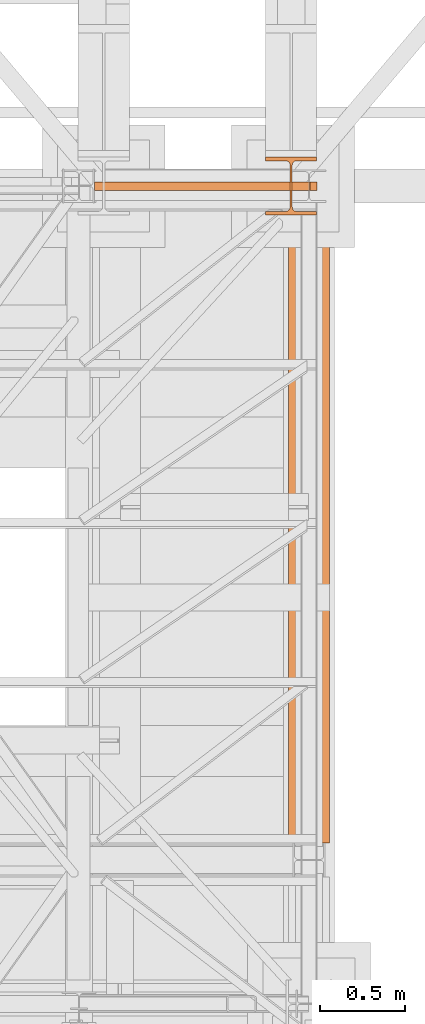
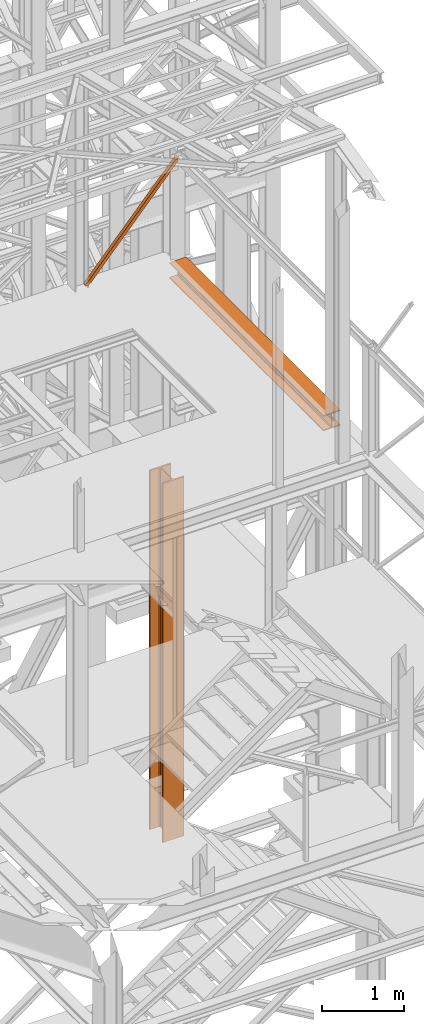
# One storey, part 77 of 208: 4 proxies.
"""IFC2X3 building model written with IfcOpenShell, lengths in millimetres."""

from ifc_helpers import new_model, entity, si_unit, converted_unit, frame, origin, origin_with_axes, place, context, subcontext, project, spatial, faceted_brep, material, element, save


model = new_model("IFC2X3")

# Units and contexts
model_context = context("Model", 3, precision=1e-05, world=origin())
plan_context = context("Plan", 3, precision=1e-05, world=origin())
body_context = subcontext(model_context, "Body", "Model", "MODEL_VIEW")
ifc_project = project(units=[si_unit("LENGTHUNIT", "METRE", prefix="MILLI"), converted_unit("PLANEANGLEUNIT", "DEGREE", entity("IfcPlaneAngleMeasure", 0.0174532925199433), si_unit("PLANEANGLEUNIT", "RADIAN"), dimensions=[0, 0, 0, 0, 0, 0, 0]), si_unit("AREAUNIT", "SQUARE_METRE"), si_unit("VOLUMEUNIT", "CUBIC_METRE")], contexts=[model_context, plan_context])

# Building, storey
building_placement = place(None, origin())
building = spatial("IfcBuilding", under=ifc_project, at=building_placement, CompositionType="COMPLEX")
storey_placement = place(building_placement, origin_with_axes())
storey = spatial("IfcBuildingStorey", under=building, at=storey_placement, Name="Geschoss", CompositionType="ELEMENT")

# Proxies
proxy_1_placement = place(storey_placement, frame((5439.095270376241, -17287.57439069042, 8485.574208086276), z_axis=(0.0, 0.0, 1.0), x_axis=(1.0, 0.0, 0.0)))
element("IfcBuildingElementProxy", 1, at=proxy_1_placement, inside=storey, context=body_context, shape_type="Brep", body=[
    faceted_brep([(0.01000000000203727, 0.01000000000203727, 19.53013193269908), (0.01000000000021828, 50.0100007450601, 19.53013193269908), (1263.785232156482, 50.01000074506374, 1439.925067016871), (1263.785232156482, 0.01000000000567525, 1439.925067016871), (0.01000000000021828, 50.0100007450601, 19.53013193269908), (0.01000000000203727, 50.0100007450601, 0.00999999999839929), (49.56811921901408, 50.0100007450601, 0.00999999999839929), (1303.220088081416, 50.01000074506374, 1409.027095462408), (1304.510962990664, 50.01000074506374, 1438.117904338131), (1263.785232156482, 50.01000074506374, 1439.925067016871), (49.56811921901408, 50.0100007450601, 0.00999999999839929), (49.56811921901408, 0.01000000000203727, 0.00999999999839929), (1303.220088081418, 0.01000000000567525, 1409.02709546241), (1303.220088081416, 50.01000074506374, 1409.027095462408), (49.56811921901408, 0.01000000000203727, 0.00999999999839929), (0.01000000000203727, 0.01000000000203727, 0.00999999999839929), (0.01000000000203727, 0.01000000000203727, 19.53013193269908), (1263.785232156482, 0.01000000000567525, 1439.925067016871), (1304.510962990664, 0.01000000000567525, 1438.117904338131), (1303.220088081418, 0.01000000000567525, 1409.02709546241), (1263.785232156482, 0.01000000000567525, 1439.925067016871), (1263.785232156482, 50.01000074506374, 1439.925067016871), (1304.510962990664, 50.01000074506374, 1438.117904338131), (1304.510962990664, 0.01000000000567525, 1438.117904338131), (1304.510962990664, 50.01000074506374, 1438.117904338131), (1303.220088081416, 50.01000074506374, 1409.027095462408), (1303.220088081418, 0.01000000000567525, 1409.02709546241), (1304.510962990664, 0.01000000000567525, 1438.117904338131), (0.01000000000203727, 50.0100007450601, 0.00999999999839929), (0.01000000000203727, 0.01000000000203727, 0.00999999999839929), (49.56811921901408, 0.01000000000203727, 0.00999999999839929), (49.56811921901408, 50.0100007450601, 0.00999999999839929), (0.01000000000021828, 50.0100007450601, 19.53013193269908), (0.01000000000203727, 0.01000000000203727, 19.53013193269908), (0.01000000000203727, 0.01000000000203727, 0.00999999999839929), (0.01000000000203727, 50.0100007450601, 0.00999999999839929)], [[[0, 1, 2, 3]], [[4, 5, 6, 7, 8, 9]], [[10, 11, 12, 13]], [[14, 15, 16, 17, 18, 19]], [[20, 21, 22, 23]], [[24, 25, 26, 27]], [[28, 29, 30, 31]], [[32, 33, 34, 35]]], orient=[[False], [False], [False], [False], [False], [False], [False], [False]]),
])
proxy_2_placement = place(storey_placement, frame((5439.095270376241, -17287.57439069042, 8485.574208086276), z_axis=(0.0, 0.0, 1.0), x_axis=(1.0, 0.0, 0.0)))
element("IfcBuildingElementProxy", 2, at=proxy_2_placement, inside=storey, context=body_context, shape_type="Brep", body=[
    faceted_brep([(0.01000000000203727, 0.01000000000203727, 19.53013193269908), (0.01000000000021828, 50.0100007450601, 19.53013193269908), (1263.785232156482, 50.01000074506374, 1439.925067016871), (1263.785232156482, 0.01000000000567525, 1439.925067016871), (0.01000000000021828, 50.0100007450601, 19.53013193269908), (0.01000000000203727, 50.0100007450601, 0.00999999999839929), (49.56811921901408, 50.0100007450601, 0.00999999999839929), (1303.220088081416, 50.01000074506374, 1409.027095462408), (1304.510962990664, 50.01000074506374, 1438.117904338131), (1263.785232156482, 50.01000074506374, 1439.925067016871), (49.56811921901408, 50.0100007450601, 0.00999999999839929), (49.56811921901408, 0.01000000000203727, 0.00999999999839929), (1303.220088081418, 0.01000000000567525, 1409.02709546241), (1303.220088081416, 50.01000074506374, 1409.027095462408), (49.56811921901408, 0.01000000000203727, 0.00999999999839929), (0.01000000000203727, 0.01000000000203727, 0.00999999999839929), (0.01000000000203727, 0.01000000000203727, 19.53013193269908), (1263.785232156482, 0.01000000000567525, 1439.925067016871), (1304.510962990664, 0.01000000000567525, 1438.117904338131), (1303.220088081418, 0.01000000000567525, 1409.02709546241), (1263.785232156482, 0.01000000000567525, 1439.925067016871), (1263.785232156482, 50.01000074506374, 1439.925067016871), (1304.510962990664, 50.01000074506374, 1438.117904338131), (1304.510962990664, 0.01000000000567525, 1438.117904338131), (1304.510962990664, 50.01000074506374, 1438.117904338131), (1303.220088081416, 50.01000074506374, 1409.027095462408), (1303.220088081418, 0.01000000000567525, 1409.02709546241), (1304.510962990664, 0.01000000000567525, 1438.117904338131), (0.01000000000203727, 50.0100007450601, 0.00999999999839929), (0.01000000000203727, 0.01000000000203727, 0.00999999999839929), (49.56811921901408, 0.01000000000203727, 0.00999999999839929), (49.56811921901408, 50.0100007450601, 0.00999999999839929), (0.01000000000021828, 50.0100007450601, 19.53013193269908), (0.01000000000203727, 0.01000000000203727, 19.53013193269908), (0.01000000000203727, 0.01000000000203727, 0.00999999999839929), (0.01000000000203727, 50.0100007450601, 0.00999999999839929)], [[[0, 1, 2, 3]], [[4, 5, 6, 7, 8, 9]], [[10, 11, 12, 13]], [[14, 15, 16, 17, 18, 19]], [[20, 21, 22, 23]], [[24, 25, 26, 27]], [[28, 29, 30, 31]], [[32, 33, 34, 35]]], orient=[[False], [False], [False], [False], [False], [False], [False], [False]]),
])
ifc_material = material(Name="35/80cm")
proxy_3_placement = place(storey_placement, frame((6443.254962568202, -17432.57439531565, -65.01000000000022), z_axis=(0.0, 0.0, 1.0), x_axis=(1.0, 0.0, 0.0)))
element("IfcBuildingElementProxy", 3, at=proxy_3_placement, inside=storey, material=ifc_material, context=body_context, shape_type="Brep", body=[
    faceted_brep([(300.0100119209292, 0.00999999999839929, 0.01000000000027512), (300.0100119209292, 21.51000631809075, 0.01000000000027512), (183.0100057816508, 21.51000631809075, 0.01000000000027512), (169.036290997863, 24.30682016372521, 0.01000000000027512), (158.8068282401564, 34.5362885093673, 0.01000000000027512), (156.0100060126188, 48.51000143050987, 0.01000000000027512), (156.0100060126188, 291.509994695185, 0.01000000000027512), (158.8068282401564, 305.4837150669082, 0.01000000000027512), (169.036290997863, 315.7131685113891, 0.01000000000027512), (183.0100057816508, 318.5099972581847, 0.01000000000027512), (300.0100119209292, 318.5099972581847, 0.01000000000027512), (300.0100119209292, 340.0100035762771, 0.01000000000027512), (0.01000000000021828, 340.0100035762771, 0.01000000000027512), (0.01000000000021828, 318.5099972581847, 0.01000000000027512), (117.0100061392786, 318.5099972581847, 0.01000000000027512), (130.9837209230664, 315.7131685113891, 0.01000000000027512), (141.213183680773, 305.4837150669082, 0.01000000000027512), (144.0100059083106, 291.509994695185, 0.01000000000027512), (144.0100059083106, 48.51000143050987, 0.01000000000027512), (141.213183680773, 34.5362885093673, 0.01000000000027512), (130.9837209230664, 24.30682016372521, 0.01000000000027512), (117.0100061392786, 21.51000631809075, 0.01000000000027512), (0.01000000000021828, 21.51000631809075, 0.01000000000027512), (0.01000000000021828, 0.00999999999839929, 0.01000000000027512), (300.0100119209292, 21.51000631809075, 5350.010005364416), (300.0100119209292, 0.00999999999839929, 5350.010005364416), (0.01000000000021828, 0.00999999999839929, 5350.010005364416), (0.01000000000021828, 21.51000631809075, 5350.010005364416), (117.0100061392786, 21.51000631809075, 5350.010005364416), (130.9837209230664, 24.30682016372521, 5350.010005364416), (141.213183680773, 34.5362885093673, 5350.010005364416), (144.0100059083106, 48.51000143050987, 5350.010005364416), (144.0100059083106, 291.509994695185, 5350.010005364416), (141.213183680773, 305.4837150669082, 5350.010005364416), (130.9837209230664, 315.7131685113891, 5350.010005364416), (117.0100061392786, 318.5099972581847, 5350.010005364416), (0.01000000000021828, 318.5099972581847, 5350.010005364416), (0.01000000000021828, 340.0100035762771, 5350.010005364416), (300.0100119209292, 340.0100035762771, 5350.010005364416), (300.0100119209292, 318.5099972581847, 5350.010005364416), (183.0100057816508, 318.5099972581847, 5350.010005364416), (169.036290997863, 315.7131685113891, 5350.010005364416), (158.8068282401564, 305.4837150669082, 5350.010005364416), (156.0100060126188, 291.509994695185, 5350.010005364416), (156.0100060126188, 48.51000143050987, 5350.010005364416), (158.8068282401564, 34.5362885093673, 5350.010005364416), (169.036290997863, 24.30682016372521, 5350.010005364416), (183.0100057816508, 21.51000631809075, 5350.010005364416), (300.0100119209292, 21.51000631809075, 0.01000000000027512), (300.0100119209292, 0.00999999999839929, 0.01000000000027512), (300.0100119209292, 0.00999999999839929, 5350.010005364416), (300.0100119209292, 21.51000631809075, 5350.010005364416), (183.0100057816508, 21.51000631809075, 0.01000000000027512), (300.0100119209292, 21.51000631809075, 0.01000000000027512), (300.0100119209292, 21.51000631809075, 5350.010005364416), (183.0100057816508, 21.51000631809075, 5350.010005364416), (169.036290997863, 24.30682016372521, 0.01000000000027512), (183.0100057816508, 21.51000631809075, 0.01000000000027512), (183.0100057816508, 21.51000631809075, 5350.010005364416), (169.036290997863, 24.30682016372521, 5350.010005364416), (158.8068282401564, 34.5362885093673, 0.01000000000027512), (169.036290997863, 24.30682016372521, 0.01000000000027512), (169.036290997863, 24.30682016372521, 5350.010005364416), (158.8068282401564, 34.5362885093673, 5350.010005364416), (156.0100060126188, 48.51000143050987, 0.01000000000027512), (158.8068282401564, 34.5362885093673, 0.01000000000027512), (158.8068282401564, 34.5362885093673, 5350.010005364416), (156.0100060126188, 48.51000143050987, 5350.010005364416), (156.0100060126188, 291.509994695185, 0.01000000000027512), (156.0100060126188, 48.51000143050987, 0.01000000000027512), (156.0100060126188, 48.51000143050987, 5350.010005364416), (156.0100060126188, 291.509994695185, 5350.010005364416), (158.8068282401564, 305.4837150669082, 0.01000000000027512), (156.0100060126188, 291.509994695185, 0.01000000000027512), (156.0100060126188, 291.509994695185, 5350.010005364416), (158.8068282401564, 305.4837150669082, 5350.010005364416), (169.036290997863, 315.7131685113891, 0.01000000000027512), (158.8068282401564, 305.4837150669082, 0.01000000000027512), (158.8068282401564, 305.4837150669082, 5350.010005364416), (169.036290997863, 315.7131685113891, 5350.010005364416), (183.0100057816508, 318.5099972581847, 0.01000000000027512), (169.036290997863, 315.7131685113891, 0.01000000000027512), (169.036290997863, 315.7131685113891, 5350.010005364416), (183.0100057816508, 318.5099972581847, 5350.010005364416), (300.0100119209292, 318.5099972581847, 0.01000000000027512), (183.0100057816508, 318.5099972581847, 0.01000000000027512), (183.0100057816508, 318.5099972581847, 5350.010005364416), (300.0100119209292, 318.5099972581847, 5350.010005364416), (300.0100119209292, 340.0100035762771, 0.01000000000027512), (300.0100119209292, 318.5099972581847, 0.01000000000027512), (300.0100119209292, 318.5099972581847, 5350.010005364416), (300.0100119209292, 340.0100035762771, 5350.010005364416), (0.01000000000021828, 340.0100035762771, 0.01000000000027512), (300.0100119209292, 340.0100035762771, 0.01000000000027512), (300.0100119209292, 340.0100035762771, 5350.010005364416), (0.01000000000021828, 340.0100035762771, 5350.010005364416), (0.01000000000021828, 318.5099972581847, 0.01000000000027512), (0.01000000000021828, 340.0100035762771, 0.01000000000027512), (0.01000000000021828, 340.0100035762771, 5350.010005364416), (0.01000000000021828, 318.5099972581847, 5350.010005364416), (117.0100061392786, 318.5099972581847, 0.01000000000027512), (0.01000000000021828, 318.5099972581847, 0.01000000000027512), (0.01000000000021828, 318.5099972581847, 5350.010005364416), (117.0100061392786, 318.5099972581847, 5350.010005364416), (130.9837209230664, 315.7131685113891, 0.01000000000027512), (117.0100061392786, 318.5099972581847, 0.01000000000027512), (117.0100061392786, 318.5099972581847, 5350.010005364416), (130.9837209230664, 315.7131685113891, 5350.010005364416), (141.213183680773, 305.4837150669082, 0.01000000000027512), (130.9837209230664, 315.7131685113891, 0.01000000000027512), (130.9837209230664, 315.7131685113891, 5350.010005364416), (141.213183680773, 305.4837150669082, 5350.010005364416), (144.0100059083106, 291.509994695185, 0.01000000000027512), (141.213183680773, 305.4837150669082, 0.01000000000027512), (141.213183680773, 305.4837150669082, 5350.010005364416), (144.0100059083106, 291.509994695185, 5350.010005364416), (144.0100059083106, 48.51000143050987, 0.01000000000027512), (144.0100059083106, 291.509994695185, 0.01000000000027512), (144.0100059083106, 291.509994695185, 5350.010005364416), (144.0100059083106, 48.51000143050987, 5350.010005364416), (141.213183680773, 34.5362885093673, 0.01000000000027512), (144.0100059083106, 48.51000143050987, 0.01000000000027512), (144.0100059083106, 48.51000143050987, 5350.010005364416), (141.213183680773, 34.5362885093673, 5350.010005364416), (130.9837209230664, 24.30682016372521, 0.01000000000027512), (141.213183680773, 34.5362885093673, 0.01000000000027512), (141.213183680773, 34.5362885093673, 5350.010005364416), (130.9837209230664, 24.30682016372521, 5350.010005364416), (117.0100061392786, 21.51000631809075, 0.01000000000027512), (130.9837209230664, 24.30682016372521, 0.01000000000027512), (130.9837209230664, 24.30682016372521, 5350.010005364416), (117.0100061392786, 21.51000631809075, 5350.010005364416), (0.01000000000021828, 21.51000631809075, 0.01000000000027512), (117.0100061392786, 21.51000631809075, 0.01000000000027512), (117.0100061392786, 21.51000631809075, 5350.010005364416), (0.01000000000021828, 21.51000631809075, 5350.010005364416), (0.01000000000021828, 0.00999999999839929, 0.01000000000027512), (0.01000000000021828, 21.51000631809075, 0.01000000000027512), (0.01000000000021828, 21.51000631809075, 5350.010005364416), (0.01000000000021828, 0.00999999999839929, 5350.010005364416), (300.0100119209292, 0.00999999999839929, 0.01000000000027512), (0.01000000000021828, 0.00999999999839929, 0.01000000000027512), (0.01000000000021828, 0.00999999999839929, 5350.010005364416), (300.0100119209292, 0.00999999999839929, 5350.010005364416)], [[[0, 1, 2, 3, 4, 5, 6, 7, 8, 9, 10, 11, 12, 13, 14, 15, 16, 17, 18, 19, 20, 21, 22, 23]], [[24, 25, 26, 27, 28, 29, 30, 31, 32, 33, 34, 35, 36, 37, 38, 39, 40, 41, 42, 43, 44, 45, 46, 47]], [[48, 49, 50, 51]], [[52, 53, 54, 55]], [[56, 57, 58, 59]], [[60, 61, 62, 63]], [[64, 65, 66, 67]], [[68, 69, 70, 71]], [[72, 73, 74, 75]], [[76, 77, 78, 79]], [[80, 81, 82, 83]], [[84, 85, 86, 87]], [[88, 89, 90, 91]], [[92, 93, 94, 95]], [[96, 97, 98, 99]], [[100, 101, 102, 103]], [[104, 105, 106, 107]], [[108, 109, 110, 111]], [[112, 113, 114, 115]], [[116, 117, 118, 119]], [[120, 121, 122, 123]], [[124, 125, 126, 127]], [[128, 129, 130, 131]], [[132, 133, 134, 135]], [[136, 137, 138, 139]], [[140, 141, 142, 143]]], orient=[[False], [False], [False], [False], [False], [False], [False], [False], [False], [False], [False], [False], [False], [False], [False], [False], [False], [False], [False], [False], [False], [False], [False], [False], [False], [False]]),
])
proxy_4_placement = place(storey_placement, frame((6578.254963760297, -21117.57438882777, 8254.989997913835), z_axis=(0.0, 0.0, 1.0), x_axis=(1.0, 0.0, 0.0)))
element("IfcBuildingElementProxy", 4, at=proxy_4_placement, inside=storey, context=body_context, shape_type="Brep", body=[
    faceted_brep([(0.01000000000021828, 0.00999999999839929, 0.01000000000021828), (240.0100095367416, 0.01000000000203727, 0.01000000000021828), (240.0100095367434, 3760.010000926439, 0.01000000000021828), (0.01000000000112777, 3760.010000926439, 0.01000000000021828), (0.01000000000021828, 0.00999999999839929, 12.0100019669535), (0.01000000000021828, 0.00999999999839929, 0.01000000000021828), (0.01000000000112777, 3760.010000926439, 0.01000000000021828), (0.01000000000112777, 3760.010000926439, 12.0100019669535), (95.2600030398371, 0.00999999999839929, 12.0100019669535), (0.01000000000021828, 0.00999999999839929, 12.0100019669535), (0.01000000000112777, 3760.010000926439, 12.0100019669535), (95.26000303983801, 3760.010000926439, 12.0100019669535), (106.1284490099552, 0.01000000000203727, 14.18530328035376), (95.2600030398371, 0.00999999999839929, 12.0100019669535), (95.26000303983801, 3760.010000926439, 12.0100019669535), (106.1284490099561, 3760.010000926439, 14.18530328035376), (114.0846986493471, 0.00999999999839929, 22.14155478239081), (106.1284490099552, 0.01000000000203727, 14.18530328035376), (106.1284490099561, 3760.010000926439, 14.18530328035376), (114.084698649348, 3760.010000926439, 22.14155478239081), (116.2600046193602, 0.01000000000203727, 33.00999982118628), (114.0846986493471, 0.00999999999839929, 22.14155478239081), (114.084698649348, 3760.010000926439, 22.14155478239081), (116.2600046193602, 3760.010000926439, 33.00999982118628), (116.2600046193602, 0.00999999999839929, 197.0100043511357), (116.2600046193602, 0.01000000000203727, 33.00999982118628), (116.2600046193602, 3760.010000926439, 33.00999982118628), (116.2600046193611, 3760.010000926439, 197.0100043511357), (114.0846986493471, 0.00999999999839929, 207.8784493899311), (116.2600046193602, 0.00999999999839929, 197.0100043511357), (116.2600046193611, 3760.010000926439, 197.0100043511357), (114.084698649348, 3760.010000926439, 207.8784493899311), (106.1284490099552, 0.01000000000203727, 215.8347008919682), (114.0846986493471, 0.00999999999839929, 207.8784493899311), (114.084698649348, 3760.010000926439, 207.8784493899311), (106.1284490099561, 3760.010000926439, 215.8347008919682), (95.2600030398371, 0.00999999999839929, 218.0100022053703), (106.1284490099552, 0.01000000000203727, 215.8347008919682), (106.1284490099561, 3760.010000926439, 215.8347008919682), (95.26000303983801, 3760.010000926439, 218.0100022053684), (0.01000000000021828, 0.00999999999839929, 218.0100022053684), (95.2600030398371, 0.00999999999839929, 218.0100022053703), (95.26000303983801, 3760.010000926439, 218.0100022053684), (0.01000000000112777, 3760.010000926439, 218.0100022053684), (0.01000000000021828, 0.00999999999839929, 230.0100041723217), (0.01000000000021828, 0.00999999999839929, 218.0100022053684), (0.01000000000112777, 3760.010000926439, 218.0100022053684), (0.01000000000112777, 3760.010000926439, 230.0100041723217), (240.0100095367416, 0.01000000000203727, 230.0100041723217), (0.01000000000021828, 0.00999999999839929, 230.0100041723217), (0.01000000000112777, 3760.010000926439, 230.0100041723217), (240.0100095367434, 3760.010000926439, 230.0100041723217), (240.0100095367416, 0.00999999999839929, 218.0100022053684), (240.0100095367416, 0.01000000000203727, 230.0100041723217), (240.0100095367434, 3760.010000926439, 230.0100041723217), (240.0100095367434, 3760.010000926439, 218.0100022053684), (144.7600064969047, 0.00999999999839929, 218.0100022053684), (240.0100095367416, 0.00999999999839929, 218.0100022053684), (240.0100095367434, 3760.010000926439, 218.0100022053684), (144.7600064969065, 3760.010000926439, 218.0100022053684), (133.8915605267866, 0.00999999999839929, 215.8347008919664), (144.7600064969047, 0.00999999999839929, 218.0100022053684), (144.7600064969065, 3760.010000926439, 218.0100022053684), (133.8915605267885, 3760.010000926439, 215.8347008919682), (125.9353108873947, 0.00999999999839929, 207.8784493899311), (133.8915605267866, 0.00999999999839929, 215.8347008919664), (133.8915605267885, 3760.010000926439, 215.8347008919682), (125.9353108873966, 3760.010000926439, 207.8784493899311), (123.7600049173816, 0.00999999999839929, 197.0100043511375), (125.9353108873947, 0.00999999999839929, 207.8784493899311), (125.9353108873966, 3760.010000926439, 207.8784493899311), (123.7600049173834, 3760.010000926439, 197.0100043511375), (123.7600049173816, 0.00999999999839929, 33.00999982118628), (123.7600049173816, 0.00999999999839929, 197.0100043511375), (123.7600049173834, 3760.010000926439, 197.0100043511375), (123.7600049173834, 3760.010000926439, 33.00999982118628), (125.9353108873956, 0.00999999999839929, 22.14155478239081), (123.7600049173816, 0.00999999999839929, 33.00999982118628), (123.7600049173834, 3760.010000926439, 33.00999982118628), (125.9353108873966, 3760.010000926439, 22.14155478239081), (133.8915605267866, 0.00999999999839929, 14.18530328035195), (125.9353108873956, 0.00999999999839929, 22.14155478239081), (125.9353108873966, 3760.010000926439, 22.14155478239081), (133.8915605267885, 3760.010000926439, 14.18530328035376), (144.7600064969047, 0.00999999999839929, 12.0100019669535), (133.8915605267866, 0.00999999999839929, 14.18530328035195), (133.8915605267885, 3760.010000926439, 14.18530328035376), (144.7600064969065, 3760.010000926439, 12.0100019669535), (240.0100095367416, 0.00999999999839929, 12.0100019669535), (144.7600064969047, 0.00999999999839929, 12.0100019669535), (144.7600064969065, 3760.010000926439, 12.0100019669535), (240.0100095367434, 3760.010000926439, 12.0100019669535), (240.0100095367416, 0.01000000000203727, 0.01000000000021828), (240.0100095367416, 0.00999999999839929, 12.0100019669535), (240.0100095367434, 3760.010000926439, 12.0100019669535), (240.0100095367434, 3760.010000926439, 0.01000000000021828), (240.0100095367434, 3760.010000926439, 0.01000000000021828), (240.0100095367434, 3760.010000926439, 12.0100019669535), (144.7600064969065, 3760.010000926439, 12.0100019669535), (133.8915605267885, 3760.010000926439, 14.18530328035376), (125.9353108873966, 3760.010000926439, 22.14155478239081), (123.7600049173834, 3760.010000926439, 33.00999982118628), (123.7600049173834, 3760.010000926439, 197.0100043511375), (125.9353108873966, 3760.010000926439, 207.8784493899311), (133.8915605267885, 3760.010000926439, 215.8347008919682), (144.7600064969065, 3760.010000926439, 218.0100022053684), (240.0100095367434, 3760.010000926439, 218.0100022053684), (240.0100095367434, 3760.010000926439, 230.0100041723217), (0.01000000000112777, 3760.010000926439, 230.0100041723217), (0.01000000000112777, 3760.010000926439, 218.0100022053684), (95.26000303983801, 3760.010000926439, 218.0100022053684), (106.1284490099561, 3760.010000926439, 215.8347008919682), (114.084698649348, 3760.010000926439, 207.8784493899311), (116.2600046193611, 3760.010000926439, 197.0100043511357), (116.2600046193602, 3760.010000926439, 33.00999982118628), (114.084698649348, 3760.010000926439, 22.14155478239081), (106.1284490099561, 3760.010000926439, 14.18530328035376), (95.26000303983801, 3760.010000926439, 12.0100019669535), (0.01000000000112777, 3760.010000926439, 12.0100019669535), (0.01000000000112777, 3760.010000926439, 0.01000000000021828), (0.01000000000021828, 0.00999999999839929, 0.01000000000021828), (0.01000000000021828, 0.00999999999839929, 12.0100019669535), (95.2600030398371, 0.00999999999839929, 12.0100019669535), (106.1284490099552, 0.01000000000203727, 14.18530328035376), (114.0846986493471, 0.00999999999839929, 22.14155478239081), (116.2600046193602, 0.01000000000203727, 33.00999982118628), (116.2600046193602, 0.00999999999839929, 197.0100043511357), (114.0846986493471, 0.00999999999839929, 207.8784493899311), (106.1284490099552, 0.01000000000203727, 215.8347008919682), (95.2600030398371, 0.00999999999839929, 218.0100022053703), (0.01000000000021828, 0.00999999999839929, 218.0100022053684), (0.01000000000021828, 0.00999999999839929, 230.0100041723217), (240.0100095367416, 0.01000000000203727, 230.0100041723217), (240.0100095367416, 0.00999999999839929, 218.0100022053684), (144.7600064969047, 0.00999999999839929, 218.0100022053684), (133.8915605267866, 0.00999999999839929, 215.8347008919664), (125.9353108873947, 0.00999999999839929, 207.8784493899311), (123.7600049173816, 0.00999999999839929, 197.0100043511375), (123.7600049173816, 0.00999999999839929, 33.00999982118628), (125.9353108873956, 0.00999999999839929, 22.14155478239081), (133.8915605267866, 0.00999999999839929, 14.18530328035195), (144.7600064969047, 0.00999999999839929, 12.0100019669535), (240.0100095367416, 0.00999999999839929, 12.0100019669535), (240.0100095367416, 0.01000000000203727, 0.01000000000021828)], [[[0, 1, 2, 3]], [[4, 5, 6, 7]], [[8, 9, 10, 11]], [[12, 13, 14, 15]], [[16, 17, 18, 19]], [[20, 21, 22, 23]], [[24, 25, 26, 27]], [[28, 29, 30, 31]], [[32, 33, 34, 35]], [[36, 37, 38, 39]], [[40, 41, 42, 43]], [[44, 45, 46, 47]], [[48, 49, 50, 51]], [[52, 53, 54, 55]], [[56, 57, 58, 59]], [[60, 61, 62, 63]], [[64, 65, 66, 67]], [[68, 69, 70, 71]], [[72, 73, 74, 75]], [[76, 77, 78, 79]], [[80, 81, 82, 83]], [[84, 85, 86, 87]], [[88, 89, 90, 91]], [[92, 93, 94, 95]], [[96, 97, 98, 99, 100, 101, 102, 103, 104, 105, 106, 107, 108, 109, 110, 111, 112, 113, 114, 115, 116, 117, 118, 119]], [[120, 121, 122, 123, 124, 125, 126, 127, 128, 129, 130, 131, 132, 133, 134, 135, 136, 137, 138, 139, 140, 141, 142, 143]]], orient=[[False], [False], [False], [False], [False], [False], [False], [False], [False], [False], [False], [False], [False], [False], [False], [False], [False], [False], [False], [False], [False], [False], [False], [False], [False], [False]]),
])

save(model, "model.ifc")
